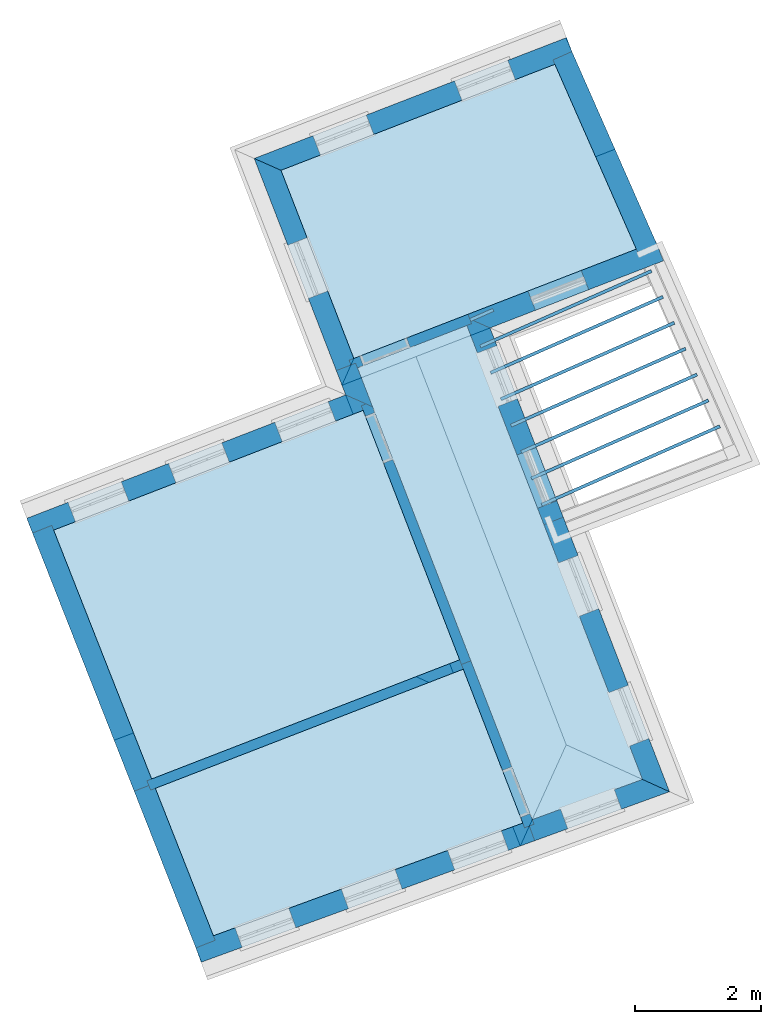
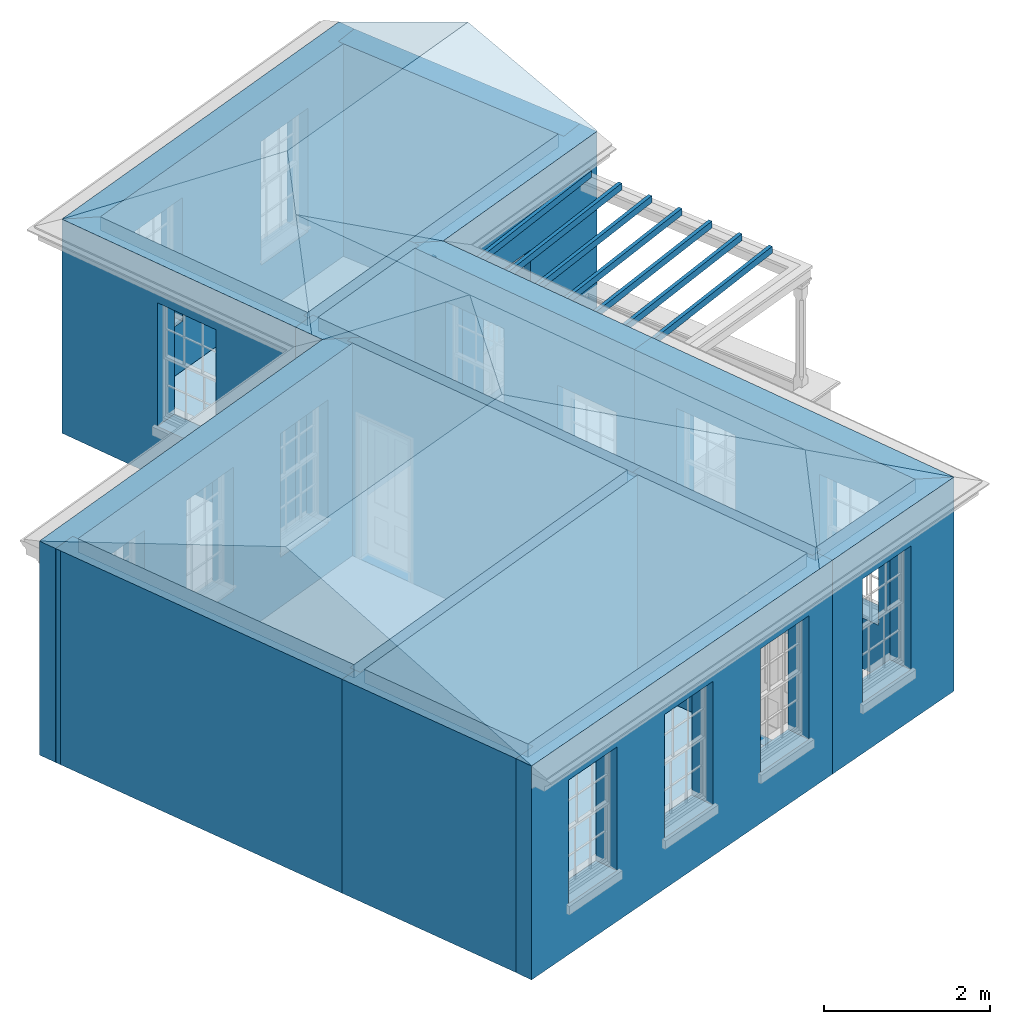
# One storey, part 1 of 11: 16 walls, 15 slabs, 3 roofs, 18 openings.
"""IFC2X3 building model written with IfcOpenShell, lengths in metres."""

from ifc_helpers import new_model, si_unit, frame, origin, place, context, subcontext, project, spatial, polyline, outline, extrude, faceted_brep, material, layer, layer_set, layer_usage, element, save


model = new_model("IFC2X3")

# Units and contexts
model_context = context("Model", 3, world=origin())
body_context = subcontext(model_context, "Body", "Model", "MODEL_VIEW")
ifc_project = project(units=[si_unit("PLANEANGLEUNIT", "RADIAN"), si_unit("MASSUNIT", "GRAM", prefix="KILO"), si_unit("FORCEUNIT", "NEWTON", prefix="KILO"), si_unit("LENGTHUNIT", "METRE")], contexts=[model_context])

# Site, building, storey
site_placement = place(None, origin())
site = spatial("IfcSite", under=ifc_project, at=site_placement, CompositionType="ELEMENT")
building_placement = place(None, origin())
building = spatial("IfcBuilding", under=site, at=building_placement, Name="Building plot-5", CompositionType="ELEMENT")
storey_placement = place(None, frame((0.0, 0.0, 7.6)))
storey = spatial("IfcBuildingStorey", under=building, at=storey_placement, Name="Floor 1", CompositionType="ELEMENT", Elevation=7.6)

# Slabs
slab_1_placement = place(storey_placement, frame((0.0, 0.0, 2.95)))
element("IfcSlab", 1, at=slab_1_placement, inside=storey, Name="Slab", ObjectType="Slab", PredefinedType="FLOOR", context=body_context, shape_type="SweptSolid", body=[
    extrude(outline(polyline([(61.89158441861, 59.2191497360491), (60.1495351743951, 58.5450434588089), (62.9319717736555, 51.3545725516665), (64.6874687237686, 51.9939267924886), (61.89158441861, 59.2191497360491)])), origin(), (0.0, 0.0, 1.0), 0.2),
])
slab_2_placement = place(storey_placement, frame((0.0, 0.0, 2.95)))
element("IfcSlab", 2, at=slab_2_placement, inside=storey, Name="Slab", ObjectType="Slab", PredefinedType="FLOOR", context=body_context, shape_type="SweptSolid", body=[
    extrude(outline(polyline([(55.3148952854796, 55.9617388030424), (56.8745247406013, 52.0014800474127), (61.7761202960995, 53.8982096280642), (60.2401145701041, 57.8676098612661), (55.3148952854796, 55.9617388030424)])), origin(), (0.0, 0.0, 1.0), 0.2),
])
slab_3_placement = place(storey_placement, frame((0.0, 0.0, 2.95)))
element("IfcSlab", 3, at=slab_3_placement, inside=storey, Name="Slab", ObjectType="Slab", PredefinedType="FLOOR", context=body_context, shape_type="SweptSolid", body=[
    extrude(outline(polyline([(58.9331084648426, 61.6885763134421), (60.0917936517026, 58.6942611405935), (64.5883185134977, 60.4342438908908), (63.2922501984706, 63.3753970596275), (58.9331084648426, 61.6885763134421)])), origin(), (0.0, 0.0, 1.0), 0.2),
])
slab_4_placement = place(storey_placement, frame((0.0, 0.0, 2.65)))
element("IfcSlab", 4, at=slab_4_placement, inside=storey, Name="Slab", ObjectType="Slab", PredefinedType="FLOOR", context=body_context, shape_type="SweptSolid", body=[
    extrude(outline(polyline([(65.9283439013394, 57.5917276781145), (65.9081814163228, 57.6374821773245), (63.0718377466658, 56.3875999203086), (63.0920002316823, 56.3418454210986), (65.9283439013394, 57.5917276781145)])), origin(), (0.0, 0.0, 1.0), 0.1),
])
slab_5_placement = place(storey_placement, frame((0.0, 0.0, 2.65)))
element("IfcSlab", 5, at=slab_5_placement, inside=storey, Name="Slab", ObjectType="Slab", PredefinedType="FLOOR", context=body_context, shape_type="SweptSolid", body=[
    extrude(outline(polyline([(65.7468815361905, 58.0035181710045), (65.726719051174, 58.0492726702145), (62.9092688722809, 56.8077161457717), (62.9294313572974, 56.7619616465617), (65.7468815361905, 58.0035181710045)])), origin(), (0.0, 0.0, 1.0), 0.1),
])
slab_6_placement = place(storey_placement, frame((0.0, 0.0, 2.65)))
element("IfcSlab", 6, at=slab_6_placement, inside=storey, Name="Slab", ObjectType="Slab", PredefinedType="FLOOR", context=body_context, shape_type="SweptSolid", body=[
    extrude(outline(polyline([(65.5654191710416, 58.4153086638945), (65.5452566860251, 58.4610631631044), (62.746699997896, 57.2278323712347), (62.7668624829125, 57.1820778720248), (65.5654191710416, 58.4153086638945)])), origin(), (0.0, 0.0, 1.0), 0.1),
])
slab_7_placement = place(storey_placement, frame((0.0, 0.0, 2.65)))
element("IfcSlab", 7, at=slab_7_placement, inside=storey, Name="Slab", ObjectType="Slab", PredefinedType="FLOOR", context=body_context, shape_type="SweptSolid", body=[
    extrude(outline(polyline([(65.3839568058928, 58.8270991567844), (65.3637943208762, 58.8728536559944), (62.5841311235111, 57.6479485966978), (62.6042936085276, 57.6021940974878), (65.3839568058928, 58.8270991567844)])), origin(), (0.0, 0.0, 1.0), 0.1),
])
slab_8_placement = place(storey_placement, frame((0.0, 0.0, 2.65)))
element("IfcSlab", 8, at=slab_8_placement, inside=storey, Name="Slab", ObjectType="Slab", PredefinedType="FLOOR", context=body_context, shape_type="SweptSolid", body=[
    extrude(outline(polyline([(65.2024944407439, 59.2388896496744), (65.1823319557273, 59.2846441488844), (62.4215622491261, 58.0680648221609), (62.4417247341427, 58.0223103229509), (65.2024944407439, 59.2388896496744)])), origin(), (0.0, 0.0, 1.0), 0.1),
])
slab_9_placement = place(storey_placement, frame((0.0, 0.0, 2.65)))
element("IfcSlab", 9, at=slab_9_placement, inside=storey, Name="Slab", ObjectType="Slab", PredefinedType="FLOOR", context=body_context, shape_type="SweptSolid", body=[
    extrude(outline(polyline([(65.021032075595, 59.6506801425644), (65.0008695905784, 59.6964346417744), (62.2589933747412, 58.488181047624), (62.2791558597578, 58.442426548414), (65.021032075595, 59.6506801425644)])), origin(), (0.0, 0.0, 1.0), 0.1),
])
slab_10_placement = place(storey_placement, frame((0.0, 0.0, 2.65)))
element("IfcSlab", 10, at=slab_10_placement, inside=storey, Name="Slab", ObjectType="Slab", PredefinedType="FLOOR", context=body_context, shape_type="SweptSolid", body=[
    extrude(outline(polyline([(64.8395697104461, 60.0624706354544), (64.8194072254296, 60.1082251346644), (62.0964245003563, 58.9082972730871), (62.1165869853729, 58.8625427738771), (64.8395697104461, 60.0624706354544)])), origin(), (0.0, 0.0, 1.0), 0.1),
])
slab_11_placement = place(storey_placement, frame((0.0, 0.0, 2.65)))
element("IfcSlab", 11, at=slab_11_placement, inside=storey, Name="Slab", ObjectType="Slab", PredefinedType="FLOOR", context=body_context, shape_type="SweptSolid", body=[
    extrude(outline(polyline([(62.3199538307068, 59.4439146920751), (62.2997913456903, 59.4896691912851), (61.9338556259714, 59.3284134985502), (61.954018110988, 59.2826589993402), (62.3199538307068, 59.4439146920751)])), origin(), (0.0, 0.0, 1.0), 0.1),
])
slab_12_placement = place(storey_placement, frame((0.0, 0.0, 2.95)))
element("IfcSlab", 12, at=slab_12_placement, inside=storey, Name="Slab", ObjectType="Slab", PredefinedType="FLOOR", context=body_context, shape_type="SweptSolid", body=[
    extrude(outline(polyline([(56.9331543264489, 51.8526060120259), (57.8571679163791, 49.5063224779304), (62.7816022096804, 51.2998077636036), (61.8338618187919, 53.7489919462796), (56.9331543264489, 51.8526060120259)])), origin(), (0.0, 0.0, 1.0), 0.2),
])
slab_13_placement = place(storey_placement, origin())
element("IfcSlab", 13, at=slab_13_placement, inside=storey, Name="Slab", ObjectType="Slab", PredefinedType="FLOOR", context=body_context, shape_type="SweptSolid", body=[
    extrude(outline(polyline([(55.3148952854796, 55.9617388030424), (56.8745247406013, 52.0014800474127), (61.7761202960995, 53.8982096280642), (60.2401145701041, 57.8676098612661), (55.3148952854796, 55.9617388030424)])), origin(), (0.0, 0.0, 1.0), 0.02),
])
slab_14_placement = place(storey_placement, origin())
element("IfcSlab", 14, at=slab_14_placement, inside=storey, Name="Slab", ObjectType="Slab", PredefinedType="FLOOR", context=body_context, shape_type="SweptSolid", body=[
    extrude(outline(polyline([(58.9331084648426, 61.6885763134421), (60.0917936517026, 58.6942611405935), (64.5883185134977, 60.4342438908908), (63.2922501984706, 63.3753970596275), (58.9331084648426, 61.6885763134421)])), origin(), (0.0, 0.0, 1.0), 0.02),
])
slab_15_placement = place(storey_placement, origin())
element("IfcSlab", 15, at=slab_15_placement, inside=storey, Name="Slab", ObjectType="Slab", PredefinedType="FLOOR", context=body_context, shape_type="SweptSolid", body=[
    extrude(outline(polyline([(56.9331543264489, 51.8526060120259), (57.8571679163791, 49.5063224779304), (62.7816022096804, 51.2998077636036), (61.8338618187919, 53.7489919462796), (56.9331543264489, 51.8526060120259)])), origin(), (0.0, 0.0, 1.0), 0.02),
])

# Wall, openings
ifc_material_1 = material(Name="Masonry")
ifc_layer_1 = layer(ifc_material_1, 0.33, ventilated=False)
ifc_layer_set_1 = layer_set([ifc_layer_1], Name="My Wall")
ifc_layer_usage_1 = layer_usage(ifc_layer_set_1, "AXIS2", "NEGATIVE", 0.08)
wall_1_placement = place(storey_placement, origin())
wall_1 = element("IfcWallStandardCase", 16, at=wall_1_placement, inside=storey, material=ifc_layer_usage_1, Name="exterior", context=body_context, shape_type="SweptSolid", body=[
    extrude(outline(polyline([(63.5966670032375, 63.4931946934615), (63.4775751126843, 63.8009561621421), (58.5062551056088, 61.8772458915696), (58.9331084648426, 61.6885763134421), (63.5966670032375, 63.4931946934615)])), origin(), (0.0, 0.0, 1.0), 3.15),
])
opening_1_placement = place(storey_placement, frame((0.0, 0.0, 0.75)))
element("IfcOpeningElement", 17, at=opening_1_placement, cuts=wall_1, Name="Opening", ObjectType="Opening", context=body_context, shape_type="SweptSolid", body=[
    extrude(outline(polyline([(62.5425065795961, 63.4391204850522), (61.6938310144464, 63.1107155747389), (61.8129229049996, 62.8029541060582), (62.6615984701493, 63.1313590163715), (62.5425065795961, 63.4391204850522)])), origin(), (0.0, 0.0, 1.0), 1.82),
])
opening_2_placement = place(storey_placement, frame((0.0, 0.0, 0.75)))
element("IfcOpeningElement", 18, at=opening_2_placement, cuts=wall_1, Name="Opening", ObjectType="Opening", context=body_context, shape_type="SweptSolid", body=[
    extrude(outline(polyline([(60.2899992038467, 62.5674864789729), (59.441323638697, 62.2390815686596), (59.5604155292502, 61.9313200999789), (60.4090910943999, 62.2597250102922), (60.2899992038467, 62.5674864789729)])), origin(), (0.0, 0.0, 1.0), 1.82),
])

# Wall, opening
wall_2_placement = place(storey_placement, origin())
wall_2 = element("IfcWallStandardCase", 19, at=wall_2_placement, inside=storey, material=ifc_layer_usage_1, Name="exterior", context=body_context, shape_type="SweptSolid", body=[
    extrude(outline(polyline([(58.9331084648426, 61.6885763134421), (58.5062551056088, 61.8772458915696), (59.8129029443682, 58.5005604091481), (60.1206644130489, 58.6196522997012), (58.9331084648426, 61.6885763134421)])), origin(), (0.0, 0.0, 1.0), 3.15),
])
opening_3_placement = place(storey_placement, frame((0.0, 0.0, 0.75)))
element("IfcOpeningElement", 20, at=opening_3_placement, cuts=wall_2, Name="Opening", ObjectType="Opening", context=body_context, shape_type="SweptSolid", body=[
    extrude(outline(polyline([(59.0404871344353, 60.4966646190395), (59.3688920447486, 59.6479890538898), (59.6766535134293, 59.767080944443), (59.348248603116, 60.6157565095927), (59.0404871344353, 60.4966646190395)])), origin(), (0.0, 0.0, 1.0), 1.82),
])

# Wall
wall_3_placement = place(storey_placement, origin())
element("IfcWallStandardCase", 21, at=wall_3_placement, inside=storey, material=ifc_layer_usage_1, Name="exterior", context=body_context, shape_type="SweptSolid", body=[
    extrude(outline(polyline([(60.1206644130489, 58.6196522997012), (59.8129029443682, 58.5005604091481), (59.9624788926549, 58.114020962086), (60.3893322518887, 57.9253513839585), (60.1206644130489, 58.6196522997012)])), origin(), (0.0, 0.0, 1.0), 3.15),
])

# Wall, openings
wall_4_placement = place(storey_placement, origin())
wall_4 = element("IfcWallStandardCase", 22, at=wall_4_placement, inside=storey, material=ifc_layer_usage_1, Name="exterior", context=body_context, shape_type="SweptSolid", body=[
    extrude(outline(polyline([(60.3893322518887, 57.9253513839585), (59.9624788926549, 58.114020962086), (54.8875965733617, 56.150236046676), (55.0066884639149, 55.8424745779954), (60.3893322518887, 57.9253513839585)])), origin(), (0.0, 0.0, 1.0), 3.15),
])
opening_4_placement = place(storey_placement, frame((0.0, 0.0, 0.75)))
element("IfcOpeningElement", 23, at=opening_4_placement, cuts=wall_4, Name="Opening", ObjectType="Opening", context=body_context, shape_type="SweptSolid", body=[
    extrude(outline(polyline([(59.6826957393088, 58.0057556070377), (58.8340201741592, 57.6773506967244), (58.9531120647123, 57.3695892280437), (59.801787629862, 57.697994138357), (59.6826957393088, 58.0057556070377)])), origin(), (0.0, 0.0, 1.0), 1.82),
])
opening_5_placement = place(storey_placement, frame((0.0, 0.0, 0.75)))
element("IfcOpeningElement", 24, at=opening_5_placement, cuts=wall_4, Name="Opening", ObjectType="Opening", context=body_context, shape_type="SweptSolid", body=[
    extrude(outline(polyline([(57.9910682995444, 57.3511606352344), (57.1423927343948, 57.0227557249211), (57.2614846249479, 56.7149942562404), (58.1101601900976, 57.0433991665537), (57.9910682995444, 57.3511606352344)])), origin(), (0.0, 0.0, 1.0), 1.82),
])
opening_6_placement = place(storey_placement, frame((0.0, 0.0, 0.75)))
element("IfcOpeningElement", 25, at=opening_6_placement, cuts=wall_4, Name="Opening", ObjectType="Opening", context=body_context, shape_type="SweptSolid", body=[
    extrude(outline(polyline([(56.3909007036071, 56.7319571169413), (55.5422251384574, 56.403552206628), (55.6613170290106, 56.0957907379473), (56.5099925941603, 56.4241956482606), (56.3909007036071, 56.7319571169413)])), origin(), (0.0, 0.0, 1.0), 1.82),
])

wall_5_placement = place(storey_placement, origin())
wall_5 = element("IfcWallStandardCase", 26, at=wall_5_placement, inside=storey, material=ifc_layer_usage_1, Name="exterior", context=body_context, shape_type="SweptSolid", body=[
    extrude(outline(polyline([(57.5490143283452, 49.3940925459324), (57.6619442351549, 49.0840170129602), (62.9712164568543, 51.017660765747), (62.8582865500446, 51.3277362987192), (57.5490143283452, 49.3940925459324)])), origin(), (0.0, 0.0, 1.0), 3.15),
])
opening_7_placement = place(storey_placement, frame((0.0, 0.0, 0.75)))
element("IfcOpeningElement", 27, at=opening_7_placement, cuts=wall_5, Name="Opening", ObjectType="Opening", context=body_context, shape_type="SweptSolid", body=[
    extrude(outline(polyline([(58.315049308065, 49.3218787181831), (59.1701060808064, 49.6332914915067), (59.0571761739967, 49.9433670244789), (58.2021194012554, 49.6319542511553), (58.315049308065, 49.3218787181831)])), origin(), (0.0, 0.0, 1.0), 1.82),
])
opening_8_placement = place(storey_placement, frame((0.0, 0.0, 0.75)))
element("IfcOpeningElement", 28, at=opening_8_placement, cuts=wall_5, Name="Opening", ObjectType="Opening", context=body_context, shape_type="SweptSolid", body=[
    extrude(outline(polyline([(60.0065048130324, 49.937908982544), (60.8615615857738, 50.2493217558676), (60.7486316789642, 50.5593972888397), (59.8935749062228, 50.2479845155161), (60.0065048130324, 49.937908982544)])), origin(), (0.0, 0.0, 1.0), 1.82),
])
opening_9_placement = place(storey_placement, frame((0.0, 0.0, 0.75)))
element("IfcOpeningElement", 29, at=opening_9_placement, cuts=wall_5, Name="Opening", ObjectType="Opening", context=body_context, shape_type="SweptSolid", body=[
    extrude(outline(polyline([(61.6979603179999, 50.5539392469048), (62.5530170907413, 50.8653520202284), (62.4400871839316, 51.1754275532006), (61.5850304111902, 50.8640147798769), (61.6979603179999, 50.5539392469048)])), origin(), (0.0, 0.0, 1.0), 1.82),
])

# Wall, opening
wall_6_placement = place(storey_placement, origin())
wall_6 = element("IfcWallStandardCase", 30, at=wall_6_placement, inside=storey, material=ifc_layer_usage_1, Name="exterior", context=body_context, shape_type="SweptSolid", body=[
    extrude(outline(polyline([(62.8582865500446, 51.3277362987192), (62.9712164568543, 51.017660765747), (65.1167215345807, 51.7990564668682), (64.6874687237686, 51.9939267924886), (62.8582865500446, 51.3277362987192)])), origin(), (0.0, 0.0, 1.0), 3.15),
])
opening_10_placement = place(storey_placement, frame((0.0, 0.0, 0.75)))
element("IfcOpeningElement", 31, at=opening_10_placement, cuts=wall_6, Name="Opening", ObjectType="Opening", context=body_context, shape_type="SweptSolid", body=[
    extrude(outline(polyline([(63.4966213275277, 51.2090138935277), (64.3516781002691, 51.5204266668513), (64.2387481934594, 51.8305021998235), (63.383691420718, 51.5190894264999), (63.4966213275277, 51.2090138935277)])), origin(), (0.0, 0.0, 1.0), 1.82),
])

# Wall, openings
wall_7_placement = place(storey_placement, origin())
wall_7 = element("IfcWallStandardCase", 32, at=wall_7_placement, inside=storey, material=ifc_layer_usage_1, Name="exterior", context=body_context, shape_type="SweptSolid", body=[
    extrude(outline(polyline([(64.6874687237686, 51.9939267924886), (65.1167215345807, 51.7990564668682), (63.4260314383826, 56.1681975114254), (63.1182699697019, 56.0491056208722), (64.6874687237686, 51.9939267924886)])), origin(), (0.0, 0.0, 1.0), 3.15),
])
opening_11_placement = place(storey_placement, frame((0.0, 0.0, 0.75)))
element("IfcOpeningElement", 33, at=opening_11_placement, cuts=wall_7, Name="Opening", ObjectType="Opening", context=body_context, shape_type="SweptSolid", body=[
    extrude(outline(polyline([(64.7892222940222, 52.6453915682585), (64.4608173837089, 53.4940671334082), (64.1530559150283, 53.374975242855), (64.4814608253416, 52.5262996777054), (64.7892222940222, 52.6453915682585)])), origin(), (0.0, 0.0, 1.0), 1.82),
])
opening_12_placement = place(storey_placement, frame((0.0, 0.0, 0.75)))
element("IfcOpeningElement", 34, at=opening_12_placement, cuts=wall_7, Name="Opening", ObjectType="Opening", context=body_context, shape_type="SweptSolid", body=[
    extrude(outline(polyline([(63.9898966937002, 54.7110370086532), (63.6614917833869, 55.5597125738029), (63.3537303147063, 55.4406206832497), (63.6821352250196, 54.5919451181), (63.9898966937002, 54.7110370086532)])), origin(), (0.0, 0.0, 1.0), 1.82),
])

wall_8_placement = place(storey_placement, origin())
wall_8 = element("IfcWallStandardCase", 35, at=wall_8_placement, inside=storey, material=ifc_layer_usage_1, Name="exterior", context=body_context, shape_type="SweptSolid", body=[
    extrude(outline(polyline([(63.1182699697019, 56.0491056208722), (63.4260314383826, 56.1681975114254), (62.2606962551514, 59.1796978397062), (61.8338428959176, 59.3683674178337), (63.1182699697019, 56.0491056208722)])), origin(), (0.0, 0.0, 1.0), 3.15),
])
opening_13_placement = place(storey_placement, frame((0.0, 0.0, 0.0199999999999996)))
element("IfcOpeningElement", 36, at=opening_13_placement, cuts=wall_8, Name="Opening", ObjectType="Opening", context=body_context, shape_type="SweptSolid", body=[
    extrude(outline(polyline([(63.3251446767321, 56.4289126431758), (62.9967397664188, 57.2775882083255), (62.6889782977382, 57.1584963177724), (63.0173832080514, 56.3098207526227), (63.3251446767321, 56.4289126431758)])), origin(), (0.0, 0.0, 1.0), 2.08),
])
opening_14_placement = place(storey_placement, frame((0.0, 0.0, 0.75)))
element("IfcOpeningElement", 37, at=opening_14_placement, cuts=wall_8, Name="Opening", ObjectType="Opening", context=body_context, shape_type="SweptSolid", body=[
    extrude(outline(polyline([(62.697366520513, 58.0512391212105), (62.3689616101998, 58.8999146863601), (62.0612001415191, 58.780822795807), (62.3896050518324, 57.9321472306573), (62.697366520513, 58.0512391212105)])), origin(), (0.0, 0.0, 1.0), 1.82),
])

# Wall, opening
wall_9_placement = place(storey_placement, origin())
wall_9 = element("IfcWallStandardCase", 38, at=wall_9_placement, inside=storey, material=ifc_layer_usage_1, Name="exterior", context=body_context, shape_type="SweptSolid", body=[
    extrude(outline(polyline([(61.8338428959176, 59.3683674178337), (62.2606962551514, 59.1796978397062), (65.0186735128031, 60.2469293132381), (64.8995816222499, 60.5546907819187), (61.8338428959176, 59.3683674178337)])), origin(), (0.0, 0.0, 1.0), 3.15),
])
opening_15_placement = place(storey_placement, frame((0.0, 0.0, 0.0199999999999996)))
element("IfcOpeningElement", 39, at=opening_15_placement, cuts=wall_9, Name="Opening", ObjectType="Opening", context=body_context, shape_type="SweptSolid", body=[
    extrude(outline(polyline([(62.9821944736141, 59.4588899921085), (63.8308700387637, 59.7872949024218), (63.7117781482106, 60.0950563711025), (62.8631025830609, 59.7666514607892), (62.9821944736141, 59.4588899921085)])), origin(), (0.0, 0.0, 1.0), 2.08),
])

# Walls
wall_10_placement = place(storey_placement, origin())
element("IfcWallStandardCase", 40, at=wall_10_placement, inside=storey, material=ifc_layer_usage_1, Name="party", context=body_context, shape_type="SweptSolid", body=[
    extrude(outline(polyline([(55.2854060298102, 56.0366188218689), (54.9783587695658, 55.9156974425498), (56.5966178105351, 51.8065646515333), (56.9036650707795, 51.9274860308524), (55.2854060298102, 56.0366188218689)])), origin(), (0.0, 0.0, 1.0), 3.15),
])
wall_11_placement = place(storey_placement, origin())
element("IfcWallStandardCase", 41, at=wall_11_placement, inside=storey, material=ifc_layer_usage_1, Name="party", context=body_context, shape_type="SweptSolid", body=[
    extrude(outline(polyline([(56.9036650707795, 51.9274860308524), (56.5966178105351, 51.8065646515333), (57.5786854214565, 49.3128685739168), (57.8857326817009, 49.4337899532359), (56.9036650707795, 51.9274860308524)])), origin(), (0.0, 0.0, 1.0), 3.15),
])
wall_12_placement = place(storey_placement, origin())
element("IfcWallStandardCase", 42, at=wall_12_placement, inside=storey, material=ifc_layer_usage_1, Name="party", context=body_context, shape_type="SweptSolid", body=[
    extrude(outline(polyline([(64.6220925570718, 60.357600835793), (64.9240722518578, 60.4906732369022), (63.5634161101529, 63.5783948302295), (63.2614364153669, 63.4453224291203), (64.6220925570718, 60.357600835793)])), origin(), (0.0, 0.0, 1.0), 3.15),
])
ifc_material_2 = material(Name="Masonry")
ifc_layer_2 = layer(ifc_material_2, 0.16, ventilated=False)
ifc_layer_set_2 = layer_set([ifc_layer_2], Name="My Wall")
ifc_layer_usage_2 = layer_usage(ifc_layer_set_2, "AXIS2", "NEGATIVE", 0.08)
wall_13_placement = place(storey_placement, origin())
element("IfcWallStandardCase", 43, at=wall_13_placement, inside=storey, material=ifc_layer_usage_2, Name="interior", context=body_context, shape_type="SweptSolid", body=[
    extrude(outline(polyline([(61.9084706596842, 53.7778627076258), (61.8507291369918, 53.9270803894104), (56.8003586099801, 51.9727805979704), (56.8581001326725, 51.8235629161858), (61.9084706596842, 53.7778627076258)])), origin(), (0.0, 0.0, 1.0), 3.15),
])

# Wall, opening
wall_14_placement = place(storey_placement, origin())
wall_14 = element("IfcWallStandardCase", 44, at=wall_14_placement, inside=storey, material=ifc_layer_usage_2, Name="interior", context=body_context, shape_type="SweptSolid", body=[
    extrude(outline(polyline([(61.9661932595023, 59.2480204973953), (61.9084517368099, 59.3972381791799), (60.0171848108104, 58.6653903792473), (60.0749263335028, 58.5161726974627), (61.9661932595023, 59.2480204973953)])), origin(), (0.0, 0.0, 1.0), 3.15),
])
opening_16_placement = place(storey_placement, frame((0.0, 0.0, 0.0199999999999996)))
element("IfcOpeningElement", 45, at=opening_16_placement, cuts=wall_14, Name="Opening", ObjectType="Opening", context=body_context, shape_type="SweptSolid", body=[
    extrude(outline(polyline([(60.9311431117408, 59.0190572057385), (60.185054702818, 58.7303495922763), (60.2427962255104, 58.5811319104917), (60.9888846344332, 58.8698395239539), (60.9311431117408, 59.0190572057385)])), origin(), (0.0, 0.0, 1.0), 2.1),
])

wall_15_placement = place(storey_placement, origin())
wall_15 = element("IfcWallStandardCase", 46, at=wall_15_placement, inside=storey, material=ifc_layer_usage_2, Name="interior", context=body_context, shape_type="SweptSolid", body=[
    extrude(outline(polyline([(60.3604614905425, 57.9999602248508), (60.2112438087579, 57.9422187021584), (61.8049910574457, 53.8236007871719), (61.9542087392303, 53.8813423098643), (60.3604614905425, 57.9999602248508)])), origin(), (0.0, 0.0, 1.0), 3.15),
])
opening_17_placement = place(storey_placement, frame((0.0, 0.0, 0.0199999999999996)))
element("IfcOpeningElement", 47, at=opening_17_placement, cuts=wall_15, Name="Opening", ObjectType="Opening", context=body_context, shape_type="SweptSolid", body=[
    extrude(outline(polyline([(60.2762030217869, 57.7743488101507), (60.5649106352492, 57.028260401228), (60.7141283170337, 57.0860019239204), (60.4254207035715, 57.8320903328432), (60.2762030217869, 57.7743488101507)])), origin(), (0.0, 0.0, 1.0), 2.1),
])

wall_16_placement = place(storey_placement, origin())
wall_16 = element("IfcWallStandardCase", 48, at=wall_16_placement, inside=storey, material=ifc_layer_usage_2, Name="interior", context=body_context, shape_type="SweptSolid", body=[
    extrude(outline(polyline([(61.9542087392303, 53.8813423098643), (61.8049910574457, 53.8236007871719), (62.8110546562577, 51.2236957111979), (62.9602723380423, 51.2814372338903), (61.9542087392303, 53.8813423098643)])), origin(), (0.0, 0.0, 1.0), 3.15),
])
opening_18_placement = place(storey_placement, frame((0.0, 0.0, 0.0199999999999996)))
element("IfcOpeningElement", 49, at=opening_18_placement, cuts=wall_16, Name="Opening", ObjectType="Opening", context=body_context, shape_type="SweptSolid", body=[
    extrude(outline(polyline([(62.4573878297665, 52.1376540121283), (62.7460954432287, 51.3915656032055), (62.8953131250133, 51.449307125898), (62.6066055115511, 52.1953955348207), (62.4573878297665, 52.1376540121283)])), origin(), (0.0, 0.0, 1.0), 2.1),
])

# Roofs
roof_1_placement = place(building_placement, origin())
element("IfcRoof", 50, at=roof_1_placement, inside=storey, Name="Roof", ShapeType="FREEFORM", context=body_context, shape_type="Brep", held_by="IfcProductRepresentation", body=[
    faceted_brep([(62.320051, 59.026311, 10.75), (54.886205, 56.149698, 10.75), (56.276857, 52.618512, 12.321976), (60.126853, 54.064335, 12.338964), (57.66795, 49.086204, 10.75), (65.116722, 51.799056, 10.75)], [[[0, 1, 2, 3]], [[4, 5, 3, 2]], [[5, 4, 1, 0]], [[5, 0, 3]], [[1, 4, 2]]]),
])
roof_2_placement = place(building_placement, origin())
element("IfcRoof", 51, at=roof_2_placement, inside=storey, Name="Roof", ShapeType="FREEFORM", context=body_context, shape_type="Brep", held_by="IfcProductRepresentation", body=[
    faceted_brep([(65.116722, 51.799056, 10.75), (60.863827, 62.789536, 10.75), (60.141186, 61.154605, 11.273551), (63.4726, 52.545448, 11.273551), (58.506255, 61.877246, 10.75), (62.74095, 50.933797, 10.75)], [[[0, 1, 2, 3]], [[4, 5, 3, 2]], [[5, 4, 1, 0]], [[5, 0, 3]], [[1, 4, 2]]]),
])
roof_3_placement = place(building_placement, origin())
element("IfcRoof", 52, at=roof_3_placement, inside=storey, Name="Roof", ShapeType="FREEFORM", context=body_context, shape_type="Brep", held_by="IfcProductRepresentation", body=[
    faceted_brep([(59.903124, 58.267408, 10.75), (65.029616, 60.251164, 10.75), (64.24837, 62.024038, 11.551644), (61.009609, 60.770761, 11.551644), (63.467123, 63.796912, 10.75), (58.506255, 61.877246, 10.75)], [[[0, 1, 2, 3]], [[4, 5, 3, 2]], [[5, 4, 1, 0]], [[5, 0, 3]], [[1, 4, 2]]]),
])

save(model, "model.ifc")
